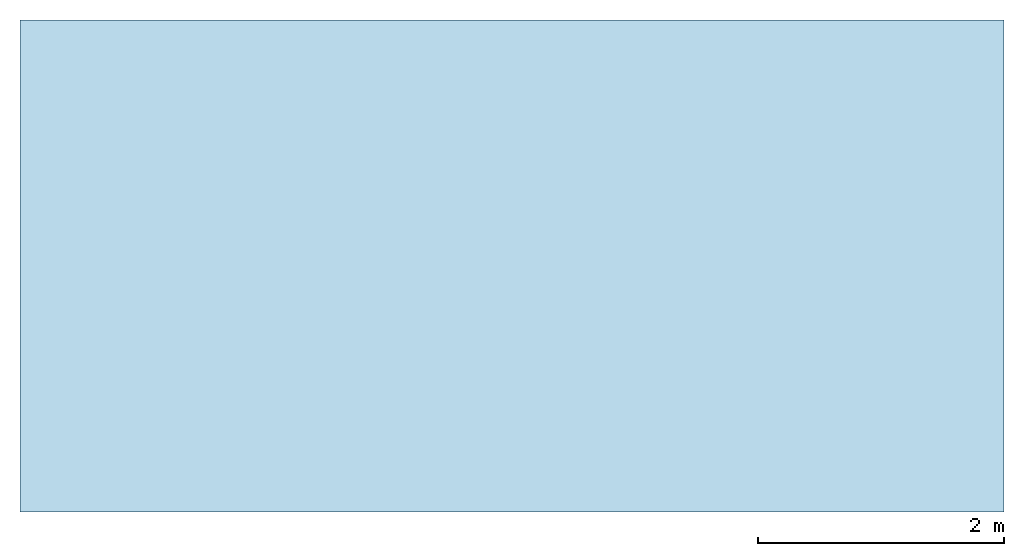
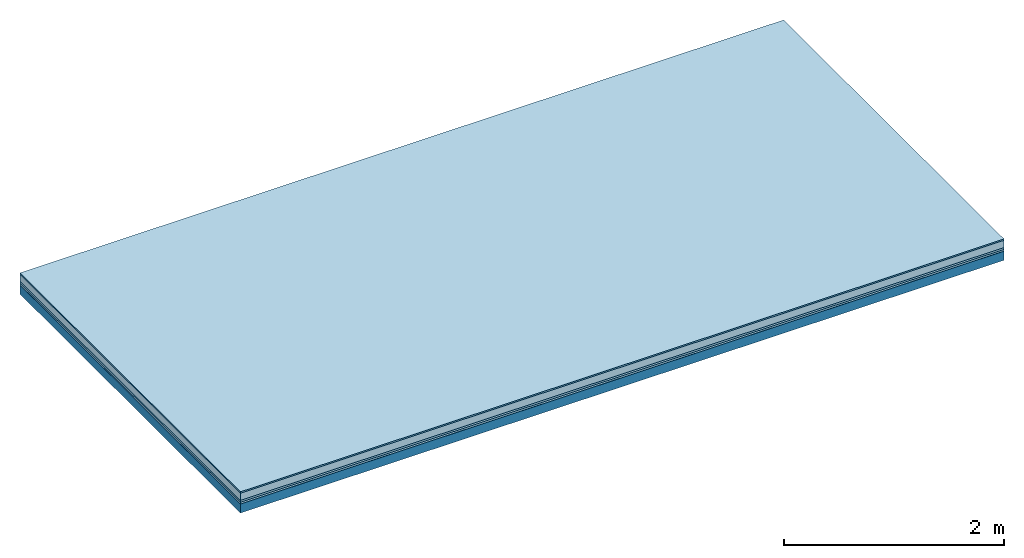
# One storey: 5 plates, 1 member, 1 element without a shape of its own.
"""IFC4 building model written with IfcOpenShell, lengths in metres."""

from ifc_helpers import new_model, si_unit, derived_unit, direction, frame, frame_2d, origin, origin_with_axes, place, context, project, spatial, rectangle, extrude, material, layer, layer_set, type_object, element, aggregate, save


model = new_model("IFC4")

# Units and contexts
plan_context = context("Plan", 3, precision=1e-05, world=origin(), true_north=direction((0.0, 1.0)))
model_context = context("Model", 3, precision=1e-05, world=origin(), true_north=direction((0.0, 1.0)))
ifc_project = project(units=[si_unit("LENGTHUNIT", "METRE"), derived_unit("SOUNDPRESSUREUNIT", [(si_unit("PRESSUREUNIT", "PASCAL", prefix="MICRO"), 0)]), si_unit("ENERGYUNIT", "JOULE", prefix="MEGA"), si_unit("MASSUNIT", "GRAM", prefix="KILO"), derived_unit("THERMALTRANSMITTANCEUNIT", [(si_unit("POWERUNIT", "WATT"), 1), (si_unit("AREAUNIT", "SQUARE_METRE"), -1), (si_unit("THERMODYNAMICTEMPERATUREUNIT", "KELVIN"), -1)]), derived_unit("AREADENSITYUNIT", [(si_unit("MASSUNIT", "GRAM", prefix="KILO"), 1), (si_unit("AREAUNIT", "SQUARE_METRE"), -1)]), derived_unit("USERDEFINED", [(si_unit("ENERGYUNIT", "JOULE", prefix="MEGA"), 1), (si_unit("AREAUNIT", "SQUARE_METRE"), -1)])], contexts=[plan_context, model_context])

# Site, building, storey
site = spatial("IfcSite", under=ifc_project)
building_placement = place(None, origin())
building = spatial("IfcBuilding", under=site, at=building_placement)
storey_placement = place(building_placement, origin())
storey = spatial("IfcBuildingStorey", under=building, at=storey_placement)

# Slab, member, plates
ifc_material_1 = material(Category="11.013")
ifc_layer_1 = layer(ifc_material_1, 0.015, Name="Flooring")
ifc_material_2 = material(Name="Cement screed", Category="04.006")
ifc_layer_2 = layer(ifc_material_2, 0.08, Name="On-material")
ifc_material_3 = material(Name="Wood fiber generic product", Category="10.009")
ifc_layer_3 = layer(ifc_material_3, 0.02, Name="Impact sound insulation")
ifc_material_4 = material()
ifc_layer_4 = layer(ifc_material_4, 0.02, Name="Additional insulation")
ifc_material_5 = material(Name="protection", Category="09.007")
ifc_layer_5 = layer(ifc_material_5, 0.0005, Name="Sub-floor")
ifc_material_6 = material(Name="no composite action")
ifc_layer_6 = layer(ifc_material_6, 0.0, Name="Bond")
ifc_layer_7 = layer(None, 0.1, Name="Supporting structure")
ifc_layer_set = layer_set([ifc_layer_1, ifc_layer_2, ifc_layer_3, ifc_layer_4, ifc_layer_5, ifc_layer_6, ifc_layer_7])
slab_type = type_object("IfcSlabType", Name="A2068", PredefinedType="NOTDEFINED", material=ifc_layer_set)
slab_placement = place(None, frame((0.0, 0.0, 0.0), z_axis=(0.0, 0.0, -1.0), x_axis=(1.0, 0.0, 0.0)))
slab = element("IfcSlab", 1, at=slab_placement, inside=storey, type_object=slab_type, material=ifc_layer_set, Name="Slab #1")
ifc_material_7 = material(Name="Solid timber panel")
member_placement = place(slab_placement, origin())
member = element("IfcMember", 2, at=member_placement, material=ifc_material_7, Name="Supporting structure", context=plan_context, shape_type="SweptSolid", body=[
    extrude(rectangle(XDim=1.0, YDim=0.1, at=frame_2d((0.5, 0.05), x_axis=(1.0, 0.0))), frame((0.0, 4.0, 0.1355), z_axis=(0.0, -1.0, 0.0), x_axis=(1.0, 0.0, 0.0)), (0.0, 0.0, 1.0), 4.0),
    extrude(rectangle(XDim=1.0, YDim=0.1, at=frame_2d((0.5, 0.05), x_axis=(1.0, 0.0))), frame((1.0, 4.0, 0.1355), z_axis=(0.0, -1.0, 0.0), x_axis=(1.0, 0.0, 0.0)), (0.0, 0.0, 1.0), 4.0),
    extrude(rectangle(XDim=1.0, YDim=0.1, at=frame_2d((0.5, 0.05), x_axis=(1.0, 0.0))), frame((2.0, 4.0, 0.1355), z_axis=(0.0, -1.0, 0.0), x_axis=(1.0, 0.0, 0.0)), (0.0, 0.0, 1.0), 4.0),
    extrude(rectangle(XDim=1.0, YDim=0.1, at=frame_2d((0.5, 0.05), x_axis=(1.0, 0.0))), frame((3.0, 4.0, 0.1355), z_axis=(0.0, -1.0, 0.0), x_axis=(1.0, 0.0, 0.0)), (0.0, 0.0, 1.0), 4.0),
    extrude(rectangle(XDim=1.0, YDim=0.1, at=frame_2d((0.5, 0.05), x_axis=(1.0, 0.0))), frame((4.0, 4.0, 0.1355), z_axis=(0.0, -1.0, 0.0), x_axis=(1.0, 0.0, 0.0)), (0.0, 0.0, 1.0), 4.0),
    extrude(rectangle(XDim=1.0, YDim=0.1, at=frame_2d((0.5, 0.05), x_axis=(1.0, 0.0))), frame((5.0, 4.0, 0.1355), z_axis=(0.0, -1.0, 0.0), x_axis=(1.0, 0.0, 0.0)), (0.0, 0.0, 1.0), 4.0),
    extrude(rectangle(XDim=1.0, YDim=0.1, at=frame_2d((0.5, 0.05), x_axis=(1.0, 0.0))), frame((6.0, 4.0, 0.1355), z_axis=(0.0, -1.0, 0.0), x_axis=(1.0, 0.0, 0.0)), (0.0, 0.0, 1.0), 4.0),
    extrude(rectangle(XDim=1.0, YDim=0.1, at=frame_2d((0.5, 0.05), x_axis=(1.0, 0.0))), frame((7.0, 4.0, 0.1355), z_axis=(0.0, -1.0, 0.0), x_axis=(1.0, 0.0, 0.0)), (0.0, 0.0, 1.0), 4.0),
])
plate_1_placement = place(slab_placement, origin())
plate_1 = element("IfcPlate", 3, at=plate_1_placement, material=ifc_material_1, Name="Flooring", context=plan_context, shape_type="SweptSolid", body=[
    extrude(rectangle(XDim=8.0, YDim=4.0, at=frame_2d((4.0, 2.0), x_axis=(1.0, 0.0))), origin_with_axes(), (0.0, 0.0, 1.0), 0.015),
])
plate_2_placement = place(slab_placement, origin())
plate_2 = element("IfcPlate", 4, at=plate_2_placement, material=ifc_material_2, Name="On-material", context=plan_context, shape_type="SweptSolid", body=[
    extrude(rectangle(XDim=8.0, YDim=4.0, at=frame_2d((4.0, 2.0), x_axis=(1.0, 0.0))), frame((0.0, 0.0, 0.015), z_axis=(0.0, 0.0, 1.0), x_axis=(1.0, 0.0, 0.0)), (0.0, 0.0, 1.0), 0.08),
])
plate_3_placement = place(slab_placement, origin())
plate_3 = element("IfcPlate", 5, at=plate_3_placement, material=ifc_material_3, Name="Impact sound insulation", context=plan_context, shape_type="SweptSolid", body=[
    extrude(rectangle(XDim=8.0, YDim=4.0, at=frame_2d((4.0, 2.0), x_axis=(1.0, 0.0))), frame((0.0, 0.0, 0.095), z_axis=(0.0, 0.0, 1.0), x_axis=(1.0, 0.0, 0.0)), (0.0, 0.0, 1.0), 0.02),
])
plate_4_placement = place(slab_placement, origin())
plate_4 = element("IfcPlate", 6, at=plate_4_placement, material=ifc_material_4, Name="Additional insulation", context=plan_context, shape_type="SweptSolid", body=[
    extrude(rectangle(XDim=8.0, YDim=4.0, at=frame_2d((4.0, 2.0), x_axis=(1.0, 0.0))), frame((0.0, 0.0, 0.115), z_axis=(0.0, 0.0, 1.0), x_axis=(1.0, 0.0, 0.0)), (0.0, 0.0, 1.0), 0.02),
])
plate_5_placement = place(slab_placement, origin())
plate_5 = element("IfcPlate", 7, at=plate_5_placement, material=ifc_material_5, Name="Sub-floor", context=plan_context, shape_type="SweptSolid", body=[
    extrude(rectangle(XDim=8.0, YDim=4.0, at=frame_2d((4.0, 2.0), x_axis=(1.0, 0.0))), frame((0.0, 0.0, 0.135), z_axis=(0.0, 0.0, 1.0), x_axis=(1.0, 0.0, 0.0)), (0.0, 0.0, 1.0), 0.0005),
])
aggregate(slab, [plate_1, plate_2, plate_3, plate_4, plate_5, member])

save(model, "model.ifc")
